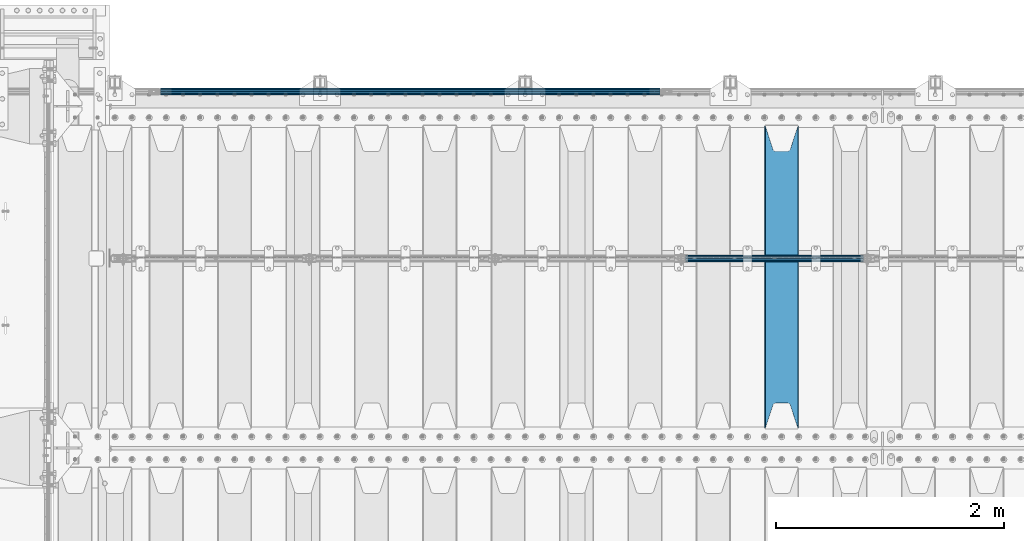
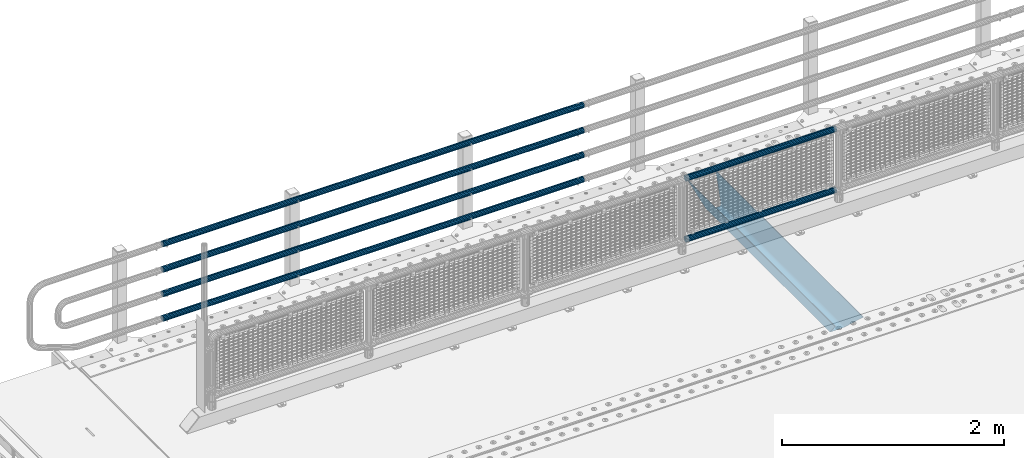
# One storey, part 117 of 242: 7 beams.
"""IFC2X3 building model written with IfcOpenShell, lengths in millimetres."""

from ifc_helpers import new_model, si_unit, frame, origin_with_axes, place, context, subcontext, project, spatial, faceted_brep, material, type_object, element, save


model = new_model("IFC2X3")

# Units and contexts
model_context = context("Model", 3, precision=1e-05, world=origin_with_axes())
body_context = subcontext(model_context, "Body", "Model", "MODEL_VIEW")
ifc_project = project(units=[si_unit("LENGTHUNIT", "METRE", prefix="MILLI"), si_unit("AREAUNIT", "SQUARE_METRE"), si_unit("VOLUMEUNIT", "CUBIC_METRE"), si_unit("MASSUNIT", "GRAM", prefix="KILO"), si_unit("TIMEUNIT", "SECOND"), si_unit("PLANEANGLEUNIT", "RADIAN"), si_unit("SOLIDANGLEUNIT", "STERADIAN"), si_unit("THERMODYNAMICTEMPERATUREUNIT", "DEGREE_CELSIUS"), si_unit("LUMINOUSINTENSITYUNIT", "LUMEN")], contexts=[model_context])

# Site, building, storey
site_placement = place(None, origin_with_axes())
site = spatial("IfcSite", under=ifc_project, at=site_placement, CompositionType="ELEMENT")
building_placement = place(site_placement, origin_with_axes())
building = spatial("IfcBuilding", under=site, at=building_placement, Name="Standard", CompositionType="ELEMENT")
storey_placement = place(building_placement, origin_with_axes())
storey = spatial("IfcBuildingStorey", under=building, at=storey_placement, Name="Undefined", CompositionType="ELEMENT", Elevation=0.0)

# Beams
ifc_material_1 = material()
beam_type_1 = type_object("IfcBeamType", PredefinedType="NOTDEFINED")
beam_1_placement = place(storey_placement, frame((-36895.15, -19335.5, 969.849999999999), z_axis=(0.0, 0.0, 1.0), x_axis=(1.0, 0.0, 0.0)))
element("IfcBeam", 1, at=beam_1_placement, inside=storey, type_object=beam_type_1, material=ifc_material_1, context=body_context, shape_type="Brep", body=[
    faceted_brep([(0.0, -25.3499999999985, 0.0), (0.0, -23.4203461491597, 9.70102501045403), (1563.0, -23.4203461491597, 9.70102501045506), (1563.0, -25.3499999999985, 0.0), (0.0, -17.9251569030785, 17.9251569030785), (1563.0, -17.9251569030785, 17.925156903079), (0.0, -9.70102501045403, 23.4203461491597), (1563.0, -9.70102501045403, 23.4203461491611), (0.0, 0.0, 25.3499999999985), (1563.0, 0.0, 25.35), (0.0, 9.70102501045403, 23.4203461491597), (1563.0, 9.70102501045403, 23.4203461491611), (0.0, 17.9251569030785, 17.9251569030785), (1563.0, 17.9251569030785, 17.925156903079), (0.0, 23.4203461491597, 9.70102501045403), (1563.0, 23.4203461491597, 9.70102501045506), (0.0, 25.3499999999985, 0.0), (1563.0, 25.3499999999985, 0.0), (0.0, 23.4203461491597, -9.70102501045403), (1563.0, 23.4203461491597, -9.70102501045506), (0.0, 17.9251569030785, -17.9251569030785), (1563.0, 17.9251569030785, -17.925156903079), (0.0, 9.70102501045403, -23.4203461491597), (1563.0, 9.70102501045403, -23.4203461491611), (0.0, 0.0, -25.3499999999985), (1563.0, 0.0, -25.35), (0.0, -9.70102501045403, -23.4203461491597), (1563.0, -9.70102501045403, -23.4203461491611), (0.0, -17.9251569030785, -17.9251569030785), (1563.0, -17.9251569030785, -17.925156903079), (0.0, -23.4203461491597, -9.70102501045403), (1563.0, -23.4203461491597, -9.70102501045506), (0.0, -30.1500000000015, 0.0), (0.0, -27.8549679052157, -11.5379054858058), (1563.0, -27.8549679052157, -11.5379054858075), (1563.0, -30.1500000000015, 0.0), (0.0, -21.3192694527752, -21.3192694527752), (1563.0, -21.3192694527752, -21.3192694527744), (0.0, -11.5379054858058, -27.8549679052157), (1563.0, -11.5379054858058, -27.8549679052153), (0.0, 0.0, -30.1500000000015), (1563.0, 0.0, -30.15), (0.0, 11.5379054858058, -27.8549679052157), (1563.0, 11.5379054858058, -27.8549679052153), (0.0, 21.3192694527752, -21.3192694527752), (1563.0, 21.3192694527752, -21.3192694527744), (0.0, 27.8549679052157, -11.5379054858058), (1563.0, 27.8549679052157, -11.5379054858074), (0.0, 30.1500000000015, 0.0), (1563.0, 30.1500000000015, 0.0), (0.0, 27.8549679052157, 11.5379054858058), (1563.0, 27.8549679052157, 11.5379054858074), (0.0, 21.3192694527752, 21.3192694527752), (1563.0, 21.3192694527752, 21.3192694527744), (0.0, 11.5379054858058, 27.8549679052157), (1563.0, 11.5379054858058, 27.8549679052153), (0.0, 0.0, 30.1500000000015), (1563.0, 0.0, 30.15), (0.0, -11.5379054858058, 27.8549679052157), (1563.0, -11.5379054858058, 27.8549679052153), (0.0, -21.3192694527752, 21.3192694527752), (1563.0, -21.3192694527752, 21.3192694527744), (0.0, -27.8549679052157, 11.5379054858058), (1563.0, -27.8549679052157, 11.5379054858074)], [[[0, 1, 2, 3]], [[1, 4, 5, 2]], [[4, 6, 7, 5]], [[6, 8, 9, 7]], [[8, 10, 11, 9]], [[10, 12, 13, 11]], [[12, 14, 15, 13]], [[14, 16, 17, 15]], [[16, 18, 19, 17]], [[18, 20, 21, 19]], [[20, 22, 23, 21]], [[22, 24, 25, 23]], [[24, 26, 27, 25]], [[26, 28, 29, 27]], [[28, 30, 31, 29]], [[30, 0, 3, 31]], [[32, 33, 34, 35]], [[33, 36, 37, 34]], [[36, 38, 39, 37]], [[38, 40, 41, 39]], [[40, 42, 43, 41]], [[42, 44, 45, 43]], [[44, 46, 47, 45]], [[46, 48, 49, 47]], [[48, 50, 51, 49]], [[50, 52, 53, 51]], [[52, 54, 55, 53]], [[54, 56, 57, 55]], [[56, 58, 59, 57]], [[58, 60, 61, 59]], [[60, 62, 63, 61]], [[62, 32, 35, 63]], [[37, 39, 41, 43, 45, 47, 49, 51, 53, 55, 57, 59, 61, 63, 35, 34], [5, 7, 9, 11, 13, 15, 17, 19, 21, 23, 25, 27, 29, 31, 3, 2]], [[62, 60, 58, 56, 54, 52, 50, 48, 46, 44, 42, 40, 38, 36, 33, 32], [30, 28, 26, 24, 22, 20, 18, 16, 14, 12, 10, 8, 6, 4, 1, 0]]]),
])
beam_2_placement = place(storey_placement, frame((-36895.15, -19335.5, 298.170000000001), z_axis=(0.0, 0.0, 1.0), x_axis=(1.0, 0.0, 0.0)))
element("IfcBeam", 2, at=beam_2_placement, inside=storey, type_object=beam_type_1, material=ifc_material_1, context=body_context, shape_type="Brep", body=[
    faceted_brep([(0.0, -25.3499999999985, 0.0), (0.0, -23.4203461491597, 9.70102501045403), (1563.0, -23.4203461491597, 9.70102501045506), (1563.0, -25.3499999999985, 0.0), (0.0, -17.9251569030785, 17.9251569030785), (1563.0, -17.9251569030785, 17.925156903079), (0.0, -9.70102501045403, 23.4203461491597), (1563.0, -9.70102501045403, 23.4203461491611), (0.0, 0.0, 25.3499999999985), (1563.0, 0.0, 25.35), (0.0, 9.70102501045403, 23.4203461491597), (1563.0, 9.70102501045403, 23.4203461491611), (0.0, 17.9251569030785, 17.9251569030785), (1563.0, 17.9251569030785, 17.925156903079), (0.0, 23.4203461491597, 9.70102501045403), (1563.0, 23.4203461491597, 9.70102501045506), (0.0, 25.3499999999985, 0.0), (1563.0, 25.3499999999985, 0.0), (0.0, 23.4203461491597, -9.70102501045403), (1563.0, 23.4203461491597, -9.70102501045506), (0.0, 17.9251569030785, -17.9251569030785), (1563.0, 17.9251569030785, -17.925156903079), (0.0, 9.70102501045403, -23.4203461491597), (1563.0, 9.70102501045403, -23.4203461491611), (0.0, 0.0, -25.3499999999985), (1563.0, 0.0, -25.35), (0.0, -9.70102501045403, -23.4203461491597), (1563.0, -9.70102501045403, -23.4203461491611), (0.0, -17.9251569030785, -17.9251569030785), (1563.0, -17.9251569030785, -17.925156903079), (0.0, -23.4203461491597, -9.70102501045403), (1563.0, -23.4203461491597, -9.70102501045506), (0.0, -30.1500000000015, 0.0), (0.0, -27.8549679052157, -11.5379054858058), (1563.0, -27.8549679052157, -11.5379054858075), (1563.0, -30.1500000000015, 0.0), (0.0, -21.3192694527752, -21.3192694527752), (1563.0, -21.3192694527752, -21.3192694527744), (0.0, -11.5379054858058, -27.8549679052157), (1563.0, -11.5379054858058, -27.8549679052153), (0.0, 0.0, -30.1500000000015), (1563.0, 0.0, -30.15), (0.0, 11.5379054858058, -27.8549679052157), (1563.0, 11.5379054858058, -27.8549679052153), (0.0, 21.3192694527752, -21.3192694527752), (1563.0, 21.3192694527752, -21.3192694527744), (0.0, 27.8549679052157, -11.5379054858058), (1563.0, 27.8549679052157, -11.5379054858074), (0.0, 30.1500000000015, 0.0), (1563.0, 30.1500000000015, 0.0), (0.0, 27.8549679052157, 11.5379054858058), (1563.0, 27.8549679052157, 11.5379054858074), (0.0, 21.3192694527752, 21.3192694527752), (1563.0, 21.3192694527752, 21.3192694527744), (0.0, 11.5379054858058, 27.8549679052157), (1563.0, 11.5379054858058, 27.8549679052153), (0.0, 0.0, 30.1500000000015), (1563.0, 0.0, 30.15), (0.0, -11.5379054858058, 27.8549679052157), (1563.0, -11.5379054858058, 27.8549679052153), (0.0, -21.3192694527752, 21.3192694527752), (1563.0, -21.3192694527752, 21.3192694527744), (0.0, -27.8549679052157, 11.5379054858058), (1563.0, -27.8549679052157, 11.5379054858074)], [[[0, 1, 2, 3]], [[1, 4, 5, 2]], [[4, 6, 7, 5]], [[6, 8, 9, 7]], [[8, 10, 11, 9]], [[10, 12, 13, 11]], [[12, 14, 15, 13]], [[14, 16, 17, 15]], [[16, 18, 19, 17]], [[18, 20, 21, 19]], [[20, 22, 23, 21]], [[22, 24, 25, 23]], [[24, 26, 27, 25]], [[26, 28, 29, 27]], [[28, 30, 31, 29]], [[30, 0, 3, 31]], [[32, 33, 34, 35]], [[33, 36, 37, 34]], [[36, 38, 39, 37]], [[38, 40, 41, 39]], [[40, 42, 43, 41]], [[42, 44, 45, 43]], [[44, 46, 47, 45]], [[46, 48, 49, 47]], [[48, 50, 51, 49]], [[50, 52, 53, 51]], [[52, 54, 55, 53]], [[54, 56, 57, 55]], [[56, 58, 59, 57]], [[58, 60, 61, 59]], [[60, 62, 63, 61]], [[62, 32, 35, 63]], [[37, 39, 41, 43, 45, 47, 49, 51, 53, 55, 57, 59, 61, 63, 35, 34], [5, 7, 9, 11, 13, 15, 17, 19, 21, 23, 25, 27, 29, 31, 3, 2]], [[62, 60, 58, 56, 54, 52, 50, 48, 46, 44, 42, 40, 38, 36, 33, 32], [30, 28, 26, 24, 22, 20, 18, 16, 14, 12, 10, 8, 6, 4, 1, 0]]]),
])
beam_type_2 = type_object("IfcBeamType", PredefinedType="NOTDEFINED")
beam_3_placement = place(storey_placement, frame((-37116.0000000001, -17870.1499999999, 149.849999999726), z_axis=(0.0, 0.0, -1.0), x_axis=(-1.0, 0.0, 0.0)))
element("IfcBeam", 3, at=beam_3_placement, inside=storey, type_object=beam_type_2, material=ifc_material_1, context=body_context, shape_type="Brep", body=[
    faceted_brep([(0.0, -26.5499999999993, 0.0), (0.0, -24.5290015881765, 10.1602451292931), (4384.00249699992, -24.5290015881765, 10.1602451292931), (4384.00249699992, -26.5499999999993, 0.0), (0.0, -18.7736850405017, 18.7736850405028), (4384.00249699992, -18.7736850405017, 18.7736850405028), (0.0, -10.1602451292929, 24.5290015881747), (4384.00249699992, -10.1602451292929, 24.5290015881747), (0.0, 0.0, 26.55), (4384.00249699992, 0.0, 26.55), (0.0, 10.1602451292929, 24.5290015881747), (4384.00249699992, 10.1602451292929, 24.5290015881747), (0.0, 18.7736850405017, 18.7736850405028), (4384.00249699992, 18.7736850405017, 18.7736850405028), (0.0, 24.5290015881765, 10.1602451292931), (4384.00249699992, 24.5290015881765, 10.1602451292931), (0.0, 26.5499999999993, 0.0), (4384.00249699992, 26.5499999999993, 0.0), (0.0, 24.5290015881765, -10.1602451292931), (4384.00249699992, 24.5290015881765, -10.1602451292931), (0.0, 18.7736850405017, -18.7736850405028), (4384.00249699992, 18.7736850405017, -18.7736850405028), (0.0, 10.1602451292929, -24.5290015881747), (4384.00249699992, 10.1602451292929, -24.5290015881747), (0.0, 0.0, -26.55), (4384.00249699992, 0.0, -26.55), (0.0, -10.1602451292929, -24.5290015881747), (4384.00249699992, -10.1602451292929, -24.5290015881747), (0.0, -18.7736850405017, -18.7736850405028), (4384.00249699992, -18.7736850405017, -18.7736850405028), (0.0, -24.5290015881765, -10.1602451292931), (4384.00249699992, -24.5290015881765, -10.1602451292931), (0.0, -30.1500000000015, 0.0), (0.0, -27.8549679052157, -11.5379054858058), (4384.00249699992, -27.8549679052157, -11.5379054858075), (4384.00249699992, -30.1500000000015, 0.0), (0.0, -21.3192694527752, -21.3192694527752), (4384.00249699992, -21.3192694527752, -21.3192694527744), (0.0, -11.5379054858058, -27.8549679052157), (4384.00249699992, -11.5379054858058, -27.8549679052153), (0.0, 0.0, -30.1500000000015), (4384.00249699992, 0.0, -30.15), (0.0, 11.5379054858058, -27.8549679052157), (4384.00249699992, 11.5379054858058, -27.8549679052153), (0.0, 21.3192694527752, -21.3192694527752), (4384.00249699992, 21.3192694527752, -21.3192694527744), (0.0, 27.8549679052157, -11.5379054858058), (4384.00249699992, 27.8549679052157, -11.5379054858074), (0.0, 30.1500000000015, 0.0), (4384.00249699992, 30.1500000000015, 0.0), (0.0, 27.8549679052157, 11.5379054858058), (4384.00249699992, 27.8549679052157, 11.5379054858075), (0.0, 21.3192694527752, 21.3192694527752), (4384.00249699992, 21.3192694527752, 21.3192694527744), (0.0, 11.5379054858058, 27.8549679052157), (4384.00249699992, 11.5379054858058, 27.8549679052153), (0.0, 0.0, 30.1500000000015), (4384.00249699992, 0.0, 30.15), (0.0, -11.5379054858058, 27.8549679052157), (4384.00249699992, -11.5379054858058, 27.8549679052153), (0.0, -21.3192694527752, 21.3192694527752), (4384.00249699992, -21.3192694527752, 21.3192694527744), (0.0, -27.8549679052157, 11.5379054858058), (4384.00249699992, -27.8549679052157, 11.5379054858075)], [[[0, 1, 2, 3]], [[1, 4, 5, 2]], [[4, 6, 7, 5]], [[6, 8, 9, 7]], [[8, 10, 11, 9]], [[10, 12, 13, 11]], [[12, 14, 15, 13]], [[14, 16, 17, 15]], [[16, 18, 19, 17]], [[18, 20, 21, 19]], [[20, 22, 23, 21]], [[22, 24, 25, 23]], [[24, 26, 27, 25]], [[26, 28, 29, 27]], [[28, 30, 31, 29]], [[30, 0, 3, 31]], [[32, 33, 34, 35]], [[33, 36, 37, 34]], [[36, 38, 39, 37]], [[38, 40, 41, 39]], [[40, 42, 43, 41]], [[42, 44, 45, 43]], [[44, 46, 47, 45]], [[46, 48, 49, 47]], [[48, 50, 51, 49]], [[50, 52, 53, 51]], [[52, 54, 55, 53]], [[54, 56, 57, 55]], [[56, 58, 59, 57]], [[58, 60, 61, 59]], [[60, 62, 63, 61]], [[62, 32, 35, 63]], [[37, 39, 41, 43, 45, 47, 49, 51, 53, 55, 57, 59, 61, 63, 35, 34], [5, 7, 9, 11, 13, 15, 17, 19, 21, 23, 25, 27, 29, 31, 3, 2]], [[62, 60, 58, 56, 54, 52, 50, 48, 46, 44, 42, 40, 38, 36, 33, 32], [30, 28, 26, 24, 22, 20, 18, 16, 14, 12, 10, 8, 6, 4, 1, 0]]]),
])
beam_4_placement = place(storey_placement, frame((-37116.0000000001, -17870.1499999999, 420.149999999729), z_axis=(0.0, 0.0, -1.0), x_axis=(-1.0, 0.0, 0.0)))
element("IfcBeam", 4, at=beam_4_placement, inside=storey, type_object=beam_type_2, material=ifc_material_1, context=body_context, shape_type="Brep", body=[
    faceted_brep([(0.0, -26.5499999999993, 0.0), (0.0, -24.5290015881765, 10.1602451292931), (4384.00249699992, -24.5290015881765, 10.1602451292931), (4384.00249699992, -26.5499999999993, 0.0), (0.0, -18.7736850405017, 18.7736850405028), (4384.00249699992, -18.7736850405017, 18.7736850405028), (0.0, -10.1602451292929, 24.5290015881747), (4384.00249699992, -10.1602451292929, 24.5290015881747), (0.0, 0.0, 26.55), (4384.00249699992, 0.0, 26.55), (0.0, 10.1602451292929, 24.5290015881747), (4384.00249699992, 10.1602451292929, 24.5290015881747), (0.0, 18.7736850405017, 18.7736850405028), (4384.00249699992, 18.7736850405017, 18.7736850405028), (0.0, 24.5290015881765, 10.1602451292931), (4384.00249699992, 24.5290015881765, 10.1602451292931), (0.0, 26.5499999999993, 0.0), (4384.00249699992, 26.5499999999993, 0.0), (0.0, 24.5290015881765, -10.1602451292931), (4384.00249699992, 24.5290015881765, -10.1602451292931), (0.0, 18.7736850405017, -18.7736850405028), (4384.00249699992, 18.7736850405017, -18.7736850405028), (0.0, 10.1602451292929, -24.5290015881747), (4384.00249699992, 10.1602451292929, -24.5290015881747), (0.0, 0.0, -26.55), (4384.00249699992, 0.0, -26.55), (0.0, -10.1602451292929, -24.5290015881747), (4384.00249699992, -10.1602451292929, -24.5290015881747), (0.0, -18.7736850405017, -18.7736850405028), (4384.00249699992, -18.7736850405017, -18.7736850405028), (0.0, -24.5290015881765, -10.1602451292931), (4384.00249699992, -24.5290015881765, -10.1602451292931), (0.0, -30.1500000000015, 0.0), (0.0, -27.8549679052157, -11.5379054858058), (4384.00249699992, -27.8549679052157, -11.5379054858075), (4384.00249699992, -30.1500000000015, 0.0), (0.0, -21.3192694527752, -21.3192694527752), (4384.00249699992, -21.3192694527752, -21.3192694527744), (0.0, -11.5379054858058, -27.8549679052157), (4384.00249699992, -11.5379054858058, -27.8549679052153), (0.0, 0.0, -30.1500000000015), (4384.00249699992, 0.0, -30.15), (0.0, 11.5379054858058, -27.8549679052157), (4384.00249699992, 11.5379054858058, -27.8549679052153), (0.0, 21.3192694527752, -21.3192694527752), (4384.00249699992, 21.3192694527752, -21.3192694527744), (0.0, 27.8549679052157, -11.5379054858058), (4384.00249699992, 27.8549679052157, -11.5379054858074), (0.0, 30.1500000000015, 0.0), (4384.00249699992, 30.1500000000015, 0.0), (0.0, 27.8549679052157, 11.5379054858058), (4384.00249699992, 27.8549679052157, 11.5379054858075), (0.0, 21.3192694527752, 21.3192694527752), (4384.00249699992, 21.3192694527752, 21.3192694527744), (0.0, 11.5379054858058, 27.8549679052157), (4384.00249699992, 11.5379054858058, 27.8549679052153), (0.0, 0.0, 30.1500000000015), (4384.00249699992, 0.0, 30.15), (0.0, -11.5379054858058, 27.8549679052157), (4384.00249699992, -11.5379054858058, 27.8549679052153), (0.0, -21.3192694527752, 21.3192694527752), (4384.00249699992, -21.3192694527752, 21.3192694527744), (0.0, -27.8549679052157, 11.5379054858058), (4384.00249699992, -27.8549679052157, 11.5379054858075)], [[[0, 1, 2, 3]], [[1, 4, 5, 2]], [[4, 6, 7, 5]], [[6, 8, 9, 7]], [[8, 10, 11, 9]], [[10, 12, 13, 11]], [[12, 14, 15, 13]], [[14, 16, 17, 15]], [[16, 18, 19, 17]], [[18, 20, 21, 19]], [[20, 22, 23, 21]], [[22, 24, 25, 23]], [[24, 26, 27, 25]], [[26, 28, 29, 27]], [[28, 30, 31, 29]], [[30, 0, 3, 31]], [[32, 33, 34, 35]], [[33, 36, 37, 34]], [[36, 38, 39, 37]], [[38, 40, 41, 39]], [[40, 42, 43, 41]], [[42, 44, 45, 43]], [[44, 46, 47, 45]], [[46, 48, 49, 47]], [[48, 50, 51, 49]], [[50, 52, 53, 51]], [[52, 54, 55, 53]], [[54, 56, 57, 55]], [[56, 58, 59, 57]], [[58, 60, 61, 59]], [[60, 62, 63, 61]], [[62, 32, 35, 63]], [[37, 39, 41, 43, 45, 47, 49, 51, 53, 55, 57, 59, 61, 63, 35, 34], [5, 7, 9, 11, 13, 15, 17, 19, 21, 23, 25, 27, 29, 31, 3, 2]], [[62, 60, 58, 56, 54, 52, 50, 48, 46, 44, 42, 40, 38, 36, 33, 32], [30, 28, 26, 24, 22, 20, 18, 16, 14, 12, 10, 8, 6, 4, 1, 0]]]),
])
beam_5_placement = place(storey_placement, frame((-37116.0000000001, -17870.1499999999, 689.849999999726), z_axis=(0.0, 0.0, -1.0), x_axis=(-1.0, 0.0, 0.0)))
element("IfcBeam", 5, at=beam_5_placement, inside=storey, type_object=beam_type_2, material=ifc_material_1, context=body_context, shape_type="Brep", body=[
    faceted_brep([(0.0, -26.5499999999993, 0.0), (0.0, -24.5290015881765, 10.1602451292931), (4384.00249699992, -24.5290015881765, 10.1602451292931), (4384.00249699992, -26.5499999999993, 0.0), (0.0, -18.7736850405017, 18.7736850405028), (4384.00249699992, -18.7736850405017, 18.7736850405028), (0.0, -10.1602451292929, 24.5290015881747), (4384.00249699992, -10.1602451292929, 24.5290015881747), (0.0, 0.0, 26.55), (4384.00249699992, 0.0, 26.55), (0.0, 10.1602451292929, 24.5290015881747), (4384.00249699992, 10.1602451292929, 24.5290015881747), (0.0, 18.7736850405017, 18.7736850405028), (4384.00249699992, 18.7736850405017, 18.7736850405028), (0.0, 24.5290015881765, 10.1602451292931), (4384.00249699992, 24.5290015881765, 10.1602451292931), (0.0, 26.5499999999993, 0.0), (4384.00249699992, 26.5499999999993, 0.0), (0.0, 24.5290015881765, -10.1602451292931), (4384.00249699992, 24.5290015881765, -10.1602451292931), (0.0, 18.7736850405017, -18.7736850405028), (4384.00249699992, 18.7736850405017, -18.7736850405028), (0.0, 10.1602451292929, -24.5290015881747), (4384.00249699992, 10.1602451292929, -24.5290015881747), (0.0, 0.0, -26.55), (4384.00249699992, 0.0, -26.55), (0.0, -10.1602451292929, -24.5290015881747), (4384.00249699992, -10.1602451292929, -24.5290015881747), (0.0, -18.7736850405017, -18.7736850405028), (4384.00249699992, -18.7736850405017, -18.7736850405028), (0.0, -24.5290015881765, -10.1602451292931), (4384.00249699992, -24.5290015881765, -10.1602451292931), (0.0, -30.1500000000015, 0.0), (0.0, -27.8549679052157, -11.5379054858058), (4384.00249699992, -27.8549679052157, -11.5379054858075), (4384.00249699992, -30.1500000000015, 0.0), (0.0, -21.3192694527752, -21.3192694527752), (4384.00249699992, -21.3192694527752, -21.3192694527744), (0.0, -11.5379054858058, -27.8549679052157), (4384.00249699992, -11.5379054858058, -27.8549679052153), (0.0, 0.0, -30.1500000000015), (4384.00249699992, 0.0, -30.15), (0.0, 11.5379054858058, -27.8549679052157), (4384.00249699992, 11.5379054858058, -27.8549679052153), (0.0, 21.3192694527752, -21.3192694527752), (4384.00249699992, 21.3192694527752, -21.3192694527744), (0.0, 27.8549679052157, -11.5379054858058), (4384.00249699992, 27.8549679052157, -11.5379054858074), (0.0, 30.1500000000015, 0.0), (4384.00249699992, 30.1500000000015, 0.0), (0.0, 27.8549679052157, 11.5379054858058), (4384.00249699992, 27.8549679052157, 11.5379054858075), (0.0, 21.3192694527752, 21.3192694527752), (4384.00249699992, 21.3192694527752, 21.3192694527744), (0.0, 11.5379054858058, 27.8549679052157), (4384.00249699992, 11.5379054858058, 27.8549679052153), (0.0, 0.0, 30.1500000000015), (4384.00249699992, 0.0, 30.15), (0.0, -11.5379054858058, 27.8549679052157), (4384.00249699992, -11.5379054858058, 27.8549679052153), (0.0, -21.3192694527752, 21.3192694527752), (4384.00249699992, -21.3192694527752, 21.3192694527744), (0.0, -27.8549679052157, 11.5379054858058), (4384.00249699992, -27.8549679052157, 11.5379054858075)], [[[0, 1, 2, 3]], [[1, 4, 5, 2]], [[4, 6, 7, 5]], [[6, 8, 9, 7]], [[8, 10, 11, 9]], [[10, 12, 13, 11]], [[12, 14, 15, 13]], [[14, 16, 17, 15]], [[16, 18, 19, 17]], [[18, 20, 21, 19]], [[20, 22, 23, 21]], [[22, 24, 25, 23]], [[24, 26, 27, 25]], [[26, 28, 29, 27]], [[28, 30, 31, 29]], [[30, 0, 3, 31]], [[32, 33, 34, 35]], [[33, 36, 37, 34]], [[36, 38, 39, 37]], [[38, 40, 41, 39]], [[40, 42, 43, 41]], [[42, 44, 45, 43]], [[44, 46, 47, 45]], [[46, 48, 49, 47]], [[48, 50, 51, 49]], [[50, 52, 53, 51]], [[52, 54, 55, 53]], [[54, 56, 57, 55]], [[56, 58, 59, 57]], [[58, 60, 61, 59]], [[60, 62, 63, 61]], [[62, 32, 35, 63]], [[37, 39, 41, 43, 45, 47, 49, 51, 53, 55, 57, 59, 61, 63, 35, 34], [5, 7, 9, 11, 13, 15, 17, 19, 21, 23, 25, 27, 29, 31, 3, 2]], [[62, 60, 58, 56, 54, 52, 50, 48, 46, 44, 42, 40, 38, 36, 33, 32], [30, 28, 26, 24, 22, 20, 18, 16, 14, 12, 10, 8, 6, 4, 1, 0]]]),
])
beam_6_placement = place(storey_placement, frame((-37116.0000000001, -17870.1499999999, 969.849999999726), z_axis=(0.0, 0.0, -1.0), x_axis=(-1.0, 0.0, 0.0)))
element("IfcBeam", 6, at=beam_6_placement, inside=storey, type_object=beam_type_2, material=ifc_material_1, context=body_context, shape_type="Brep", body=[
    faceted_brep([(0.0, -26.5499999999993, 0.0), (0.0, -24.5290015881765, 10.1602451292931), (4384.00249699992, -24.5290015881765, 10.1602451292931), (4384.00249699992, -26.5499999999993, 0.0), (0.0, -18.7736850405017, 18.7736850405028), (4384.00249699992, -18.7736850405017, 18.7736850405028), (0.0, -10.1602451292929, 24.5290015881747), (4384.00249699992, -10.1602451292929, 24.5290015881747), (0.0, 0.0, 26.55), (4384.00249699992, 0.0, 26.55), (0.0, 10.1602451292929, 24.5290015881747), (4384.00249699992, 10.1602451292929, 24.5290015881747), (0.0, 18.7736850405017, 18.7736850405028), (4384.00249699992, 18.7736850405017, 18.7736850405028), (0.0, 24.5290015881765, 10.1602451292931), (4384.00249699992, 24.5290015881765, 10.1602451292931), (0.0, 26.5499999999993, 0.0), (4384.00249699992, 26.5499999999993, 0.0), (0.0, 24.5290015881765, -10.1602451292931), (4384.00249699992, 24.5290015881765, -10.1602451292931), (0.0, 18.7736850405017, -18.7736850405028), (4384.00249699992, 18.7736850405017, -18.7736850405028), (0.0, 10.1602451292929, -24.5290015881747), (4384.00249699992, 10.1602451292929, -24.5290015881747), (0.0, 0.0, -26.55), (4384.00249699992, 0.0, -26.55), (0.0, -10.1602451292929, -24.5290015881747), (4384.00249699992, -10.1602451292929, -24.5290015881747), (0.0, -18.7736850405017, -18.7736850405028), (4384.00249699992, -18.7736850405017, -18.7736850405028), (0.0, -24.5290015881765, -10.1602451292931), (4384.00249699992, -24.5290015881765, -10.1602451292931), (0.0, -30.1500000000015, 0.0), (0.0, -27.8549679052157, -11.5379054858058), (4384.00249699992, -27.8549679052157, -11.5379054858075), (4384.00249699992, -30.1500000000015, 0.0), (0.0, -21.3192694527752, -21.3192694527752), (4384.00249699992, -21.3192694527752, -21.3192694527744), (0.0, -11.5379054858058, -27.8549679052157), (4384.00249699992, -11.5379054858058, -27.8549679052153), (0.0, 0.0, -30.1500000000015), (4384.00249699992, 0.0, -30.15), (0.0, 11.5379054858058, -27.8549679052157), (4384.00249699992, 11.5379054858058, -27.8549679052153), (0.0, 21.3192694527752, -21.3192694527752), (4384.00249699992, 21.3192694527752, -21.3192694527744), (0.0, 27.8549679052157, -11.5379054858058), (4384.00249699992, 27.8549679052157, -11.5379054858074), (0.0, 30.1500000000015, 0.0), (4384.00249699992, 30.1500000000015, 0.0), (0.0, 27.8549679052157, 11.5379054858058), (4384.00249699992, 27.8549679052157, 11.5379054858075), (0.0, 21.3192694527752, 21.3192694527752), (4384.00249699992, 21.3192694527752, 21.3192694527744), (0.0, 11.5379054858058, 27.8549679052157), (4384.00249699992, 11.5379054858058, 27.8549679052153), (0.0, 0.0, 30.1500000000015), (4384.00249699992, 0.0, 30.15), (0.0, -11.5379054858058, 27.8549679052157), (4384.00249699992, -11.5379054858058, 27.8549679052153), (0.0, -21.3192694527752, 21.3192694527752), (4384.00249699992, -21.3192694527752, 21.3192694527744), (0.0, -27.8549679052157, 11.5379054858058), (4384.00249699992, -27.8549679052157, 11.5379054858075)], [[[0, 1, 2, 3]], [[1, 4, 5, 2]], [[4, 6, 7, 5]], [[6, 8, 9, 7]], [[8, 10, 11, 9]], [[10, 12, 13, 11]], [[12, 14, 15, 13]], [[14, 16, 17, 15]], [[16, 18, 19, 17]], [[18, 20, 21, 19]], [[20, 22, 23, 21]], [[22, 24, 25, 23]], [[24, 26, 27, 25]], [[26, 28, 29, 27]], [[28, 30, 31, 29]], [[30, 0, 3, 31]], [[32, 33, 34, 35]], [[33, 36, 37, 34]], [[36, 38, 39, 37]], [[38, 40, 41, 39]], [[40, 42, 43, 41]], [[42, 44, 45, 43]], [[44, 46, 47, 45]], [[46, 48, 49, 47]], [[48, 50, 51, 49]], [[50, 52, 53, 51]], [[52, 54, 55, 53]], [[54, 56, 57, 55]], [[56, 58, 59, 57]], [[58, 60, 61, 59]], [[60, 62, 63, 61]], [[62, 32, 35, 63]], [[37, 39, 41, 43, 45, 47, 49, 51, 53, 55, 57, 59, 61, 63, 35, 34], [5, 7, 9, 11, 13, 15, 17, 19, 21, 23, 25, 27, 29, 31, 3, 2]], [[62, 60, 58, 56, 54, 52, 50, 48, 46, 44, 42, 40, 38, 36, 33, 32], [30, 28, 26, 24, 22, 20, 18, 16, 14, 12, 10, 8, 6, 4, 1, 0]]]),
])
ifc_material_2 = material(Name="STEEL/S355N")
beam_type_3 = type_object("IfcBeamType", PredefinedType="NOTDEFINED")
beam_7_placement = place(storey_placement, frame((-36050.0, -20825.0, -115.0), z_axis=(0.0, 0.0, 1.0), x_axis=(0.0, 1.0, 0.0)))
element("IfcBeam", 7, at=beam_7_placement, inside=storey, type_object=beam_type_3, material=ifc_material_2, context=body_context, shape_type="Brep", body=[
    faceted_brep([(0.0, 150.0, 115.0), (0.0, 143.689999999999, 115.0), (2650.00000000297, 143.689999999999, 115.0), (2650.00000000297, 150.0, 115.0), (2650.00000000297, 142.059565218402, 110.000000003099), (2650.00000000297, 148.369565218403, 110.000000003099), (2441.90079219209, -80.1103600731112, -98.0992078077845), (2437.7588105432, -77.5672621345584, -102.241189456673), (2434.06523489747, -74.4080125315522, -105.934765102404), (2430.91086095089, -70.710272125576, -109.089139048974), (2428.37322971128, -66.5649389910068, -111.626770288588), (2426.51472138055, -62.0739139532889, -113.485278619323), (2425.38102192092, -57.3475956567672, -114.618978078955), (2424.99999999987, -52.5021667386536, -115.0), (2424.99999999987, 52.5021667386536, -115.0), (2425.38102192092, 57.3475956567672, -114.618978078955), (2426.51472138055, 62.0739139532889, -113.485278619323), (2428.37322971128, 66.5649389910068, -111.626770288588), (2430.91086095089, 70.710272125576, -109.089139048974), (2434.06523489747, 74.4080125315522, -105.934765102404), (2437.7588105432, 77.5672621345584, -102.241189456673), (2441.90079219209, 80.1103600731112, -98.0992078077846), (2446.38936140511, 81.9747917625791, -93.6106385947584), (2448.2494850041, 76.2713538057251, -91.7505149957729), (2444.62967112262, 74.76777986261, -95.3703288772456), (2441.28936334126, 72.7168944282894, -98.710636658607), (2438.31067330438, 70.1691124903846, -101.689326695487), (2435.76682334747, 67.1870637758839, -104.233176652398), (2433.72034654133, 63.8440531834895, -106.279653458539), (2432.22154950042, 60.222258798236, -107.778450499454), (2431.30727574265, 56.4107117849089, -108.692724257221), (2430.99999999987, 52.5031078186876, -109.0), (2430.99999999987, -52.5031078186876, -109.0), (2431.30727574265, -56.4107117849089, -108.692724257221), (2432.22154950042, -60.222258798236, -107.778450499454), (2433.72034654133, -63.8440531834895, -106.279653458539), (2435.76682334747, -67.1870637758839, -104.233176652398), (2438.31067330438, -70.1691124903846, -101.689326695487), (2441.28936334126, -72.7168944282894, -98.7106366586071), (2444.62967112262, -74.76777986261, -95.3703288772457), (2448.2494850041, -76.2713538057251, -91.7505149957729), (2650.00000000297, -142.059565218402, 110.000000003099), (2650.00000000297, -148.369565218403, 110.000000003099), (2446.38936140511, -81.9747917625791, -93.6106385947584), (2650.00000000297, -143.689999999999, 115.0), (2650.00000000297, -150.0, 115.0), (0.0, -143.689999999999, 115.0), (0.0, -150.0, 115.0), (0.0, -148.369565218261, 110.000000002669), (203.610638597427, -81.9747917625791, -93.6106385947584), (208.099207810454, -80.1103600731112, -98.0992078077845), (212.241189459342, -77.5672621345584, -102.241189456673), (215.934765105074, -74.4080125315522, -105.934765102404), (219.089139051644, -70.710272125576, -109.089139048974), (221.626770291256, -66.5649389910068, -111.626770288588), (223.485278621993, -62.0739139532889, -113.485278619323), (224.618978081624, -57.3475956567672, -114.618978078955), (225.00000000267, -52.5021667386536, -115.0), (225.00000000267, 52.5021667386536, -115.0), (224.618978081624, 57.3475956567672, -114.618978078955), (223.485278621993, 62.0739139532889, -113.485278619323), (221.626770291256, 66.5649389910068, -111.626770288588), (219.089139051644, 70.710272125576, -109.089139048974), (215.934765105074, 74.4080125315522, -105.934765102404), (212.241189459342, 77.5672621345584, -102.241189456673), (208.099207810454, 80.1103600731112, -98.0992078077846), (203.610638597427, 81.9747917625791, -93.6106385947584), (0.0, 148.369565218261, 110.000000002669), (0.0, 142.05956521826, 110.000000002669), (201.750514998443, 76.2713538057251, -91.7505149957729), (205.370328879915, 74.76777986261, -95.3703288772456), (208.710636661275, 72.7168944282894, -98.710636658607), (211.689326698157, 70.1691124903846, -101.689326695487), (214.233176655067, 67.1870637758839, -104.233176652398), (216.279653461206, 63.8440531834895, -106.279653458539), (217.778450502123, 60.222258798236, -107.778450499454), (218.69272425989, 56.4107117849089, -108.692724257221), (219.00000000267, 52.5031078186876, -109.0), (219.00000000267, -52.5031078186876, -109.0), (218.69272425989, -56.4107117849089, -108.692724257221), (217.778450502123, -60.222258798236, -107.778450499454), (216.279653461206, -63.8440531834895, -106.279653458539), (214.233176655067, -67.1870637758839, -104.233176652398), (211.689326698157, -70.1691124903846, -101.689326695487), (208.710636661275, -72.7168944282894, -98.7106366586071), (205.370328879915, -74.76777986261, -95.3703288772457), (201.750514998443, -76.2713538057251, -91.7505149957729), (0.0, -142.05956521826, 110.000000002669)], [[[0, 1, 2, 3]], [[3, 2, 4, 5]], [[6, 7, 8, 9, 10, 11, 12, 13, 14, 15, 16, 17, 18, 19, 20, 21, 22, 5, 4, 23, 24, 25, 26, 27, 28, 29, 30, 31, 32, 33, 34, 35, 36, 37, 38, 39, 40, 41, 42, 43]], [[44, 45, 42, 41]], [[46, 47, 45, 44]], [[43, 42, 45, 47, 48, 49]], [[6, 43, 49, 50]], [[7, 6, 50, 51]], [[8, 7, 51, 52]], [[9, 8, 52, 53]], [[10, 9, 53, 54]], [[11, 10, 54, 55]], [[12, 11, 55, 56]], [[13, 12, 56, 57]], [[14, 13, 57, 58]], [[15, 14, 58, 59]], [[16, 15, 59, 60]], [[17, 16, 60, 61]], [[18, 17, 61, 62]], [[19, 18, 62, 63]], [[20, 19, 63, 64]], [[21, 20, 64, 65]], [[22, 21, 65, 66]], [[0, 3, 5, 22, 66, 67]], [[1, 0, 67, 68]], [[23, 4, 2, 1, 68, 69]], [[24, 23, 69, 70]], [[25, 24, 70, 71]], [[26, 25, 71, 72]], [[27, 26, 72, 73]], [[28, 27, 73, 74]], [[29, 28, 74, 75]], [[30, 29, 75, 76]], [[31, 30, 76, 77]], [[32, 31, 77, 78]], [[33, 32, 78, 79]], [[34, 33, 79, 80]], [[35, 34, 80, 81]], [[36, 35, 81, 82]], [[37, 36, 82, 83]], [[38, 37, 83, 84]], [[39, 38, 84, 85]], [[40, 39, 85, 86]], [[46, 44, 41, 40, 86, 87]], [[47, 46, 87, 48]], [[86, 85, 84, 83, 82, 81, 80, 79, 78, 77, 76, 75, 74, 73, 72, 71, 70, 69, 68, 67, 66, 65, 64, 63, 62, 61, 60, 59, 58, 57, 56, 55, 54, 53, 52, 51, 50, 49, 48, 87]]]),
])

save(model, "model.ifc")
